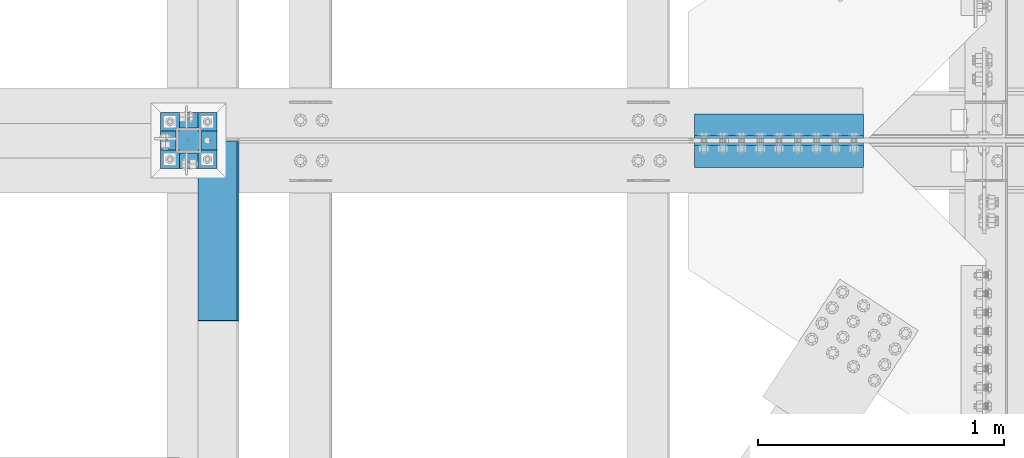
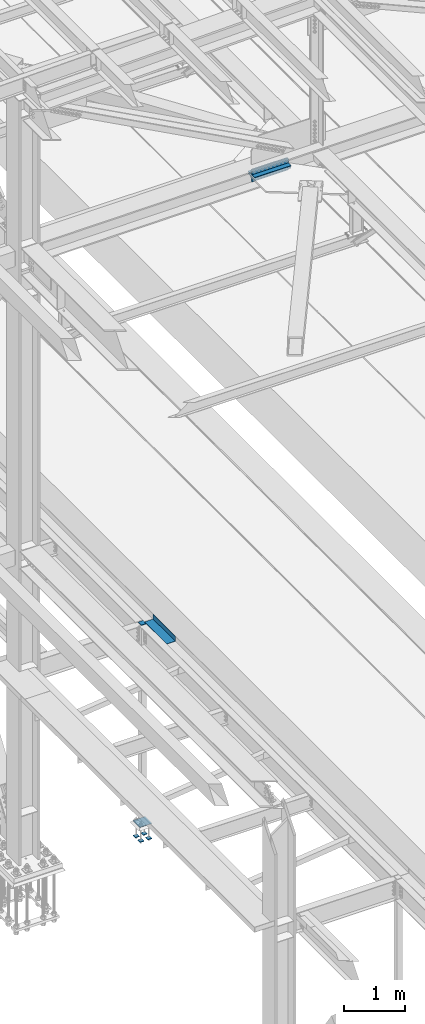
# One storey, part 2372 of 3843: 11 beams, 5 elements without a shape of their own.
"""IFC2X3 building model written with IfcOpenShell, lengths in millimetres."""

from ifc_helpers import new_model, si_unit, frame, origin_with_axes, place, context, subcontext, project, spatial, faceted_brep, material, type_object, element, aggregate, save


model = new_model("IFC2X3")

# Units and contexts
model_context = context("Model", 3, precision=1e-05, world=origin_with_axes())
body_context = subcontext(model_context, "Body", "Model", "MODEL_VIEW")
ifc_project = project(units=[si_unit("LENGTHUNIT", "METRE", prefix="MILLI"), si_unit("AREAUNIT", "SQUARE_METRE"), si_unit("VOLUMEUNIT", "CUBIC_METRE"), si_unit("MASSUNIT", "GRAM", prefix="KILO"), si_unit("TIMEUNIT", "SECOND"), si_unit("PLANEANGLEUNIT", "RADIAN"), si_unit("SOLIDANGLEUNIT", "STERADIAN"), si_unit("THERMODYNAMICTEMPERATUREUNIT", "DEGREE_CELSIUS"), si_unit("LUMINOUSINTENSITYUNIT", "LUMEN")], contexts=[model_context])

# Site, building, storey
site_placement = place(None, origin_with_axes())
site = spatial("IfcSite", under=ifc_project, at=site_placement, CompositionType="ELEMENT")
building_placement = place(site_placement, origin_with_axes())
building = spatial("IfcBuilding", under=site, at=building_placement, Name="Undefined", CompositionType="ELEMENT")
storey_placement = place(building_placement, origin_with_axes())
storey = spatial("IfcBuildingStorey", under=building, at=storey_placement, Name="Undefined", CompositionType="ELEMENT", Elevation=0.0)

# Assembly, beam
assembly_1_placement = place(storey_placement, origin_with_axes())
assembly_1 = element("IfcElementAssembly", 1, at=assembly_1_placement, inside=storey, Name="BEAM", AssemblyPlace="NOTDEFINED", PredefinedType="RIGID_FRAME")
ifc_material_1 = material(Name="STEEL/A36")
beam_type_1 = type_object("IfcBeamType", PredefinedType="NOTDEFINED")
beam_1_placement = place(assembly_1_placement, frame((38858.825, 66903.6, 34039.175), z_axis=(0.0, -1.0, 0.0), x_axis=(1.0, 0.0, 0.0)))
beam_1 = element("IfcBeam", 2, at=beam_1_placement, type_object=beam_type_1, material=ifc_material_1, Name="BENT_PLATE", context=body_context, shape_type="Brep", body=[
    faceted_brep([(161.925005912773, 7.27595761418343e-12, 365.125000000029), (158.749999999993, 3.17500000000291, 361.950000000041), (0.0, 3.17500000000291, 361.950000000041), (0.0, 0.0, 365.125), (161.924999999988, 98.4249999999956, 365.125), (158.749999999993, 98.4249999999956, 361.950000000041), (165.099999999999, -3.17500000000291, -365.125), (0.0, -3.17500000000291, -365.125), (0.0, 3.17500000000291, -365.125), (158.749999999993, 3.17500000000291, -365.125), (158.749999999993, 98.4249999999956, -365.125), (165.099999999999, 98.4249999999956, -365.125), (165.099999999999, -3.17500000000291, 365.125), (165.099999999999, 98.4249999999956, 365.125), (0.0, -3.17500000000291, 365.125)], [[[0, 1, 2, 3]], [[4, 5, 1, 0]], [[6, 7, 8, 9, 10, 11]], [[12, 6, 11, 13]], [[14, 7, 6, 12]], [[8, 7, 14, 3, 2]], [[9, 8, 2, 1]], [[10, 9, 1, 5]], [[13, 11, 10, 5, 4]], [[14, 12, 13, 4, 0, 3]]]),
])
aggregate(assembly_1, [beam_1])

# Assembly, beams
assembly_2_placement = place(storey_placement, origin_with_axes())
assembly_2 = element("IfcElementAssembly", 3, at=assembly_2_placement, inside=storey, Name="PLATE", AssemblyPlace="NOTDEFINED", PredefinedType="RIGID_FRAME")
ifc_material_2 = material(Name="STEEL/A572-50")
beam_type_2 = type_object("IfcBeamType", Name="L4X4X1/2", PredefinedType="NOTDEFINED")
beam_2_placement = place(assembly_2_placement, frame((40874.9499999991, 67329.8437499999, 42297.3500007629), z_axis=(0.0, 1.0, 0.0), x_axis=(1.0, 0.0, 0.0)))
beam_2 = element("IfcBeam", 4, at=beam_2_placement, type_object=beam_type_2, material=ifc_material_2, Name="ANGLE", ObjectType="L4X4X1/2", context=body_context, shape_type="Brep", body=[
    faceted_brep([(0.0, 50.8000000000029, -50.8000000000029), (0.0, 50.8000000000029, 50.8000000000029), (685.800000000003, 50.8000000000029, 50.8000000000029), (685.800000000003, 50.8000000000029, -50.8000000000029), (0.0, 38.0999999999985, 50.8000000000029), (685.800000000003, 38.0999999999985, 50.8000000000029), (0.0, 38.0999999999985, -38.0999999999985), (685.800000000003, 38.0999999999985, -38.1000000000058), (0.0, -50.8000000000029, -38.1000000000058), (685.800000000003, -50.8000000000029, -38.1000000000058), (0.0, -50.8000000000029, -50.8000000000029), (685.800000000003, -50.8000000000029, -50.8000000000029)], [[[0, 1, 2, 3]], [[1, 4, 5, 2]], [[4, 6, 7, 5]], [[6, 8, 9, 7]], [[8, 10, 11, 9]], [[10, 0, 3, 11]], [[5, 7, 9, 11, 3, 2]], [[10, 8, 6, 4, 1, 0]]]),
])
beam_3_placement = place(assembly_2_placement, frame((41560.7499999991, 67329.8437499999, 42167.175), z_axis=(0.0, 1.0, 0.0), x_axis=(-1.0, 0.0, 0.0)))
beam_3 = element("IfcBeam", 5, at=beam_3_placement, type_object=beam_type_2, material=ifc_material_2, Name="ANGLE", ObjectType="L4X4X1/2", context=body_context, shape_type="Brep", body=[
    faceted_brep([(0.0, 50.8000000000029, -50.8000000000029), (0.0, 50.8000000000029, 50.8000000000029), (685.800000000003, 50.8000000000029, 50.8000000000029), (685.800000000003, 50.8000000000029, -50.8000000000029), (0.0, 38.0999999999985, 50.8000000000029), (685.800000000003, 38.0999999999985, 50.8000000000029), (0.0, 38.0999999999985, -38.0999999999985), (685.800000000003, 38.0999999999985, -38.1000000000058), (0.0, -50.8000000000029, -38.1000000000058), (685.800000000003, -50.8000000000029, -38.1000000000058), (0.0, -50.8000000000029, -50.8000000000029), (685.800000000003, -50.8000000000029, -50.8000000000029)], [[[0, 1, 2, 3]], [[1, 4, 5, 2]], [[4, 6, 7, 5]], [[6, 8, 9, 7]], [[8, 10, 11, 9]], [[10, 0, 3, 11]], [[5, 7, 9, 11, 3, 2]], [[10, 8, 6, 4, 1, 0]]]),
])
aggregate(assembly_2, [beam_2, beam_3])

assembly_3_placement = place(storey_placement, origin_with_axes())
assembly_3 = element("IfcElementAssembly", 6, at=assembly_3_placement, inside=storey, Name="PLATE", AssemblyPlace="NOTDEFINED", PredefinedType="RIGID_FRAME")
beam_4_placement = place(assembly_3_placement, frame((41560.7499999991, 67213.9562499999, 42297.3500007629), z_axis=(0.0, -1.0, 0.0), x_axis=(-1.0, 0.0, 0.0)))
beam_4 = element("IfcBeam", 7, at=beam_4_placement, type_object=beam_type_2, material=ifc_material_2, Name="ANGLE", ObjectType="L4X4X1/2", context=body_context, shape_type="Brep", body=[
    faceted_brep([(0.0, 50.8000000000029, -50.8000000000029), (0.0, 50.8000000000029, 50.8000000000029), (685.800000000003, 50.8000000000029, 50.8000000000029), (685.800000000003, 50.8000000000029, -50.8000000000029), (0.0, 38.0999999999985, 50.8000000000029), (685.800000000003, 38.0999999999985, 50.8000000000029), (0.0, 38.0999999999985, -38.0999999999985), (685.800000000003, 38.0999999999985, -38.1000000000058), (0.0, -50.8000000000029, -38.1000000000058), (685.800000000003, -50.8000000000029, -38.1000000000058), (0.0, -50.8000000000029, -50.8000000000029), (685.800000000003, -50.8000000000029, -50.8000000000029)], [[[0, 1, 2, 3]], [[1, 4, 5, 2]], [[4, 6, 7, 5]], [[6, 8, 9, 7]], [[8, 10, 11, 9]], [[10, 0, 3, 11]], [[5, 7, 9, 11, 3, 2]], [[10, 8, 6, 4, 1, 0]]]),
])
beam_5_placement = place(assembly_3_placement, frame((40874.9499999991, 67213.9562499999, 42167.175), z_axis=(0.0, -1.0, 0.0), x_axis=(1.0, 0.0, 0.0)))
beam_5 = element("IfcBeam", 8, at=beam_5_placement, type_object=beam_type_2, material=ifc_material_2, Name="ANGLE", ObjectType="L4X4X1/2", context=body_context, shape_type="Brep", body=[
    faceted_brep([(0.0, 50.8000000000029, -50.8000000000029), (0.0, 50.8000000000029, 50.8000000000029), (685.800000000003, 50.8000000000029, 50.8000000000029), (685.800000000003, 50.8000000000029, -50.8000000000029), (0.0, 38.0999999999985, 50.8000000000029), (685.800000000003, 38.0999999999985, 50.8000000000029), (0.0, 38.0999999999985, -38.0999999999985), (685.800000000003, 38.0999999999985, -38.1000000000058), (0.0, -50.8000000000029, -38.1000000000058), (685.800000000003, -50.8000000000029, -38.1000000000058), (0.0, -50.8000000000029, -50.8000000000029), (685.800000000003, -50.8000000000029, -50.8000000000029)], [[[0, 1, 2, 3]], [[1, 4, 5, 2]], [[4, 6, 7, 5]], [[6, 8, 9, 7]], [[8, 10, 11, 9]], [[10, 0, 3, 11]], [[5, 7, 9, 11, 3, 2]], [[10, 8, 6, 4, 1, 0]]]),
])
aggregate(assembly_3, [beam_4, beam_5])

# Assembly, beam
assembly_4_placement = place(storey_placement, origin_with_axes())
assembly_4 = element("IfcElementAssembly", 9, at=assembly_4_placement, inside=storey, Name="COLUMN", AssemblyPlace="NOTDEFINED", PredefinedType="RIGID_FRAME")
beam_type_3 = type_object("IfcBeamType", PredefinedType="NOTDEFINED")
beam_6_placement = place(assembly_4_placement, frame((38871.525, 67271.9, 34029.65), z_axis=(0.0, 1.0, 0.0), x_axis=(-1.0, 0.0, 0.0)))
beam_6 = element("IfcBeam", 10, at=beam_6_placement, type_object=beam_type_3, material=ifc_material_2, Name="PLATE", context=body_context, shape_type="Brep", body=[
    faceted_brep([(0.0, 6.34999999999854, -50.8000000000029), (0.0, 6.35000000000582, 50.7999992361001), (101.600000000006, 6.34999999999854, 50.8000000000029), (101.600000000006, 6.34999999999854, -50.8000000000029), (0.0, -6.35000000000582, 50.7999992361001), (101.600000000006, -6.34999999999854, 50.8000000000029), (0.0, -6.34999999999854, -50.8000000000029), (101.600000000006, -6.34999999999854, -50.8000000000029)], [[[0, 1, 2, 3]], [[1, 4, 5, 2]], [[4, 6, 7, 5]], [[6, 0, 3, 7]], [[5, 7, 3, 2]], [[6, 4, 1, 0]]]),
])
aggregate(assembly_4, [beam_6])

# Assembly, beams
assembly_5_placement = place(storey_placement, origin_with_axes())
assembly_5 = element("IfcElementAssembly", 11, at=assembly_5_placement, inside=storey, Name="TEMPLATE", AssemblyPlace="NOTDEFINED", PredefinedType="RIGID_FRAME")
beam_type_4 = type_object("IfcBeamType", PredefinedType="NOTDEFINED")
beam_7_placement = place(assembly_5_placement, frame((38935.025, 67195.7, 29762.45), z_axis=(0.0, 1.0, 0.0), x_axis=(-1.0, 0.0, 0.0)))
beam_7 = element("IfcBeam", 12, at=beam_7_placement, type_object=beam_type_4, material=ifc_material_2, context=body_context, shape_type="Brep", body=[
    faceted_brep([(0.0, 6.34999999999854, -38.1000000000058), (0.0, 6.34999999999854, 38.0999984741211), (76.1999999999971, 6.34999999999854, 38.1000000000058), (76.1999999999971, 6.34999999999854, -38.1000000000058), (0.0, -6.34999999999854, 38.0999984741211), (76.1999999999971, -6.34999999999854, 38.1000000000058), (0.0, -6.34999999999854, -38.1000000000058), (76.1999999999971, -6.34999999999854, -38.1000000000058)], [[[0, 1, 2, 3]], [[1, 4, 5, 2]], [[4, 6, 7, 5]], [[6, 0, 3, 7]], [[5, 7, 3, 2]], [[6, 4, 1, 0]]]),
])
beam_8_placement = place(assembly_5_placement, frame((38935.025, 67348.1, 29762.45), z_axis=(0.0, 1.0, 0.0), x_axis=(-1.0, 0.0, 0.0)))
beam_8 = element("IfcBeam", 13, at=beam_8_placement, type_object=beam_type_4, material=ifc_material_2, context=body_context, shape_type="Brep", body=[
    faceted_brep([(0.0, 6.34999999999854, -38.1000000000058), (0.0, 6.34999999999854, 38.0999984741211), (76.1999999999971, 6.34999999999854, 38.1000000000058), (76.1999999999971, 6.34999999999854, -38.1000000000058), (0.0, -6.34999999999854, 38.0999984741211), (76.1999999999971, -6.34999999999854, 38.1000000000058), (0.0, -6.34999999999854, -38.1000000000058), (76.1999999999971, -6.34999999999854, -38.1000000000058)], [[[0, 1, 2, 3]], [[1, 4, 5, 2]], [[4, 6, 7, 5]], [[6, 0, 3, 7]], [[5, 7, 3, 2]], [[6, 4, 1, 0]]]),
])
beam_9_placement = place(assembly_5_placement, frame((38782.625, 67195.7, 29762.45), z_axis=(0.0, 1.0, 0.0), x_axis=(-1.0, 0.0, 0.0)))
beam_9 = element("IfcBeam", 14, at=beam_9_placement, type_object=beam_type_4, material=ifc_material_2, context=body_context, shape_type="Brep", body=[
    faceted_brep([(0.0, 6.34999999999854, -38.1000000000058), (0.0, 6.34999999999854, 38.0999984741211), (76.1999999999971, 6.34999999999854, 38.1000000000058), (76.1999999999971, 6.34999999999854, -38.1000000000058), (0.0, -6.34999999999854, 38.0999984741211), (76.1999999999971, -6.34999999999854, 38.1000000000058), (0.0, -6.34999999999854, -38.1000000000058), (76.1999999999971, -6.34999999999854, -38.1000000000058)], [[[0, 1, 2, 3]], [[1, 4, 5, 2]], [[4, 6, 7, 5]], [[6, 0, 3, 7]], [[5, 7, 3, 2]], [[6, 4, 1, 0]]]),
])
beam_10_placement = place(assembly_5_placement, frame((38782.625, 67348.1, 29762.45), z_axis=(0.0, 1.0, 0.0), x_axis=(-1.0, 0.0, 0.0)))
beam_10 = element("IfcBeam", 15, at=beam_10_placement, type_object=beam_type_4, material=ifc_material_2, context=body_context, shape_type="Brep", body=[
    faceted_brep([(0.0, 6.34999999999854, -38.1000000000058), (0.0, 6.34999999999854, 38.0999984741211), (76.1999999999971, 6.34999999999854, 38.1000000000058), (76.1999999999971, 6.34999999999854, -38.1000000000058), (0.0, -6.34999999999854, 38.0999984741211), (76.1999999999971, -6.34999999999854, 38.1000000000058), (0.0, -6.34999999999854, -38.1000000000058), (76.1999999999971, -6.34999999999854, -38.1000000000058)], [[[0, 1, 2, 3]], [[1, 4, 5, 2]], [[4, 6, 7, 5]], [[6, 0, 3, 7]], [[5, 7, 3, 2]], [[6, 4, 1, 0]]]),
])
beam_type_5 = type_object("IfcBeamType", PredefinedType="NOTDEFINED")
beam_11_placement = place(assembly_5_placement, frame((38935.025, 67271.9, 30062.4875), z_axis=(0.0, -1.0, 0.0), x_axis=(-1.0, 0.0, 0.0)))
beam_11 = element("IfcBeam", 16, at=beam_11_placement, type_object=beam_type_5, material=ifc_material_2, Name="TEMPLATE", context=body_context, shape_type="Brep", body=[
    faceted_brep([(0.0, 1.58750000000146, -114.300000000003), (0.0, 1.58750000000146, 114.300000000003), (228.600000000006, 1.58750000000146, 114.300000000003), (228.600000000006, 1.58750000000146, -114.300000000003), (0.0, -1.58750000000146, 114.300000000003), (228.600000000006, -1.58750000000146, 114.300000000003), (0.0, -1.58750000000146, -114.300000000003), (228.600000000006, -1.58750000000146, -114.300000000003)], [[[0, 1, 2, 3]], [[1, 4, 5, 2]], [[4, 6, 7, 5]], [[6, 0, 3, 7]], [[5, 7, 3, 2]], [[6, 4, 1, 0]]]),
])
aggregate(assembly_5, [beam_7, beam_8, beam_9, beam_10, beam_11])

save(model, "model.ifc")
